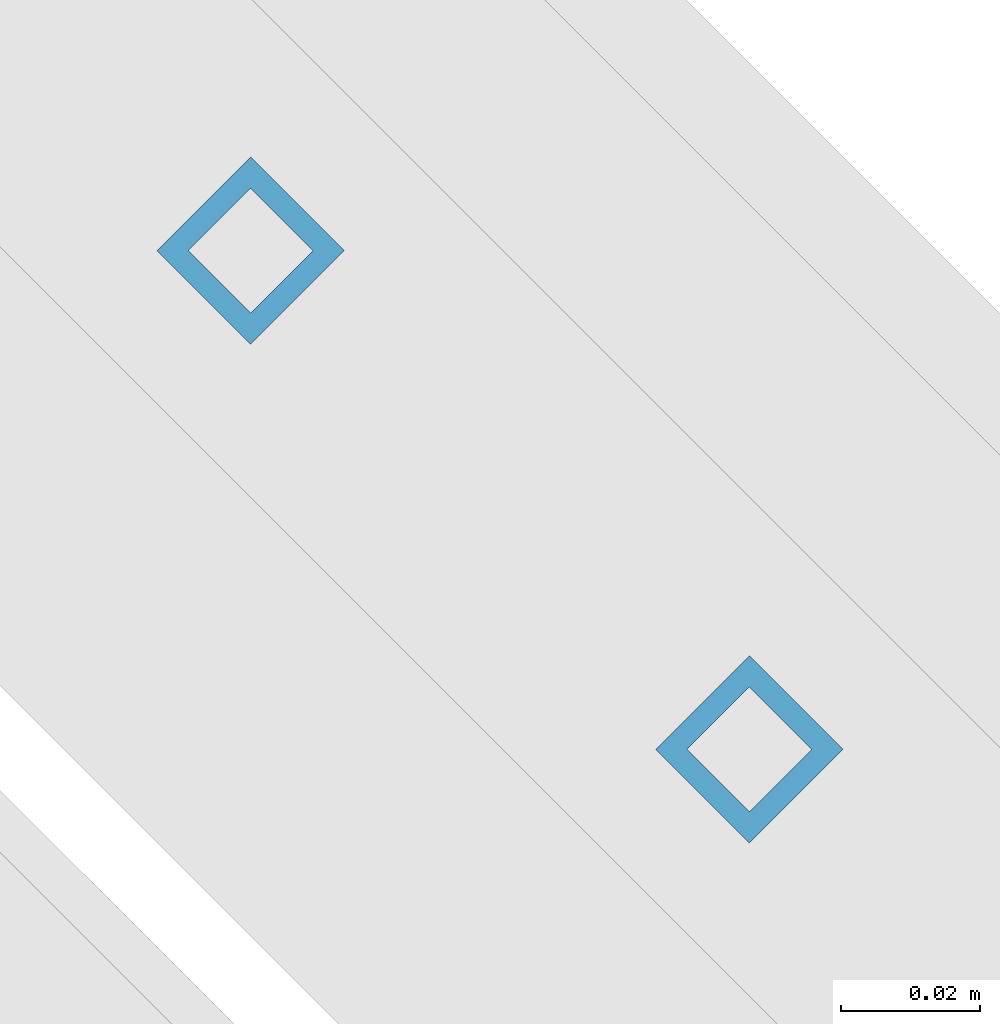
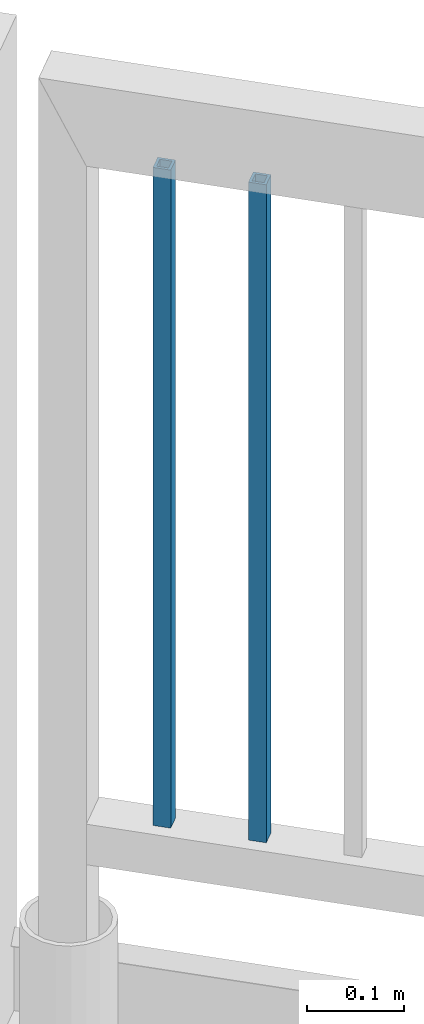
# One storey, part 247 of 975: 2 columns.
"""IFC2X3 building model written with IfcOpenShell, lengths in millimetres."""

from ifc_helpers import new_model, si_unit, frame, origin_with_axes, place, context, subcontext, project, spatial, faceted_brep, material, type_object, element, save


model = new_model("IFC2X3")

# Units and contexts
model_context = context("Model", 3, precision=1e-05, world=origin_with_axes())
body_context = subcontext(model_context, "Body", "Model", "MODEL_VIEW")
ifc_project = project(units=[si_unit("LENGTHUNIT", "METRE", prefix="MILLI"), si_unit("AREAUNIT", "SQUARE_METRE"), si_unit("VOLUMEUNIT", "CUBIC_METRE"), si_unit("MASSUNIT", "GRAM", prefix="KILO"), si_unit("TIMEUNIT", "SECOND"), si_unit("PLANEANGLEUNIT", "RADIAN"), si_unit("SOLIDANGLEUNIT", "STERADIAN"), si_unit("THERMODYNAMICTEMPERATUREUNIT", "DEGREE_CELSIUS"), si_unit("LUMINOUSINTENSITYUNIT", "LUMEN")], contexts=[model_context])

# Site, building, storey
site_placement = place(None, origin_with_axes())
site = spatial("IfcSite", under=ifc_project, at=site_placement, CompositionType="ELEMENT")
building_placement = place(site_placement, origin_with_axes())
building = spatial("IfcBuilding", under=site, at=building_placement, Name="Undefined", CompositionType="ELEMENT")
storey_placement = place(building_placement, origin_with_axes())
storey = spatial("IfcBuildingStorey", under=building, at=storey_placement, Name="Undefined", CompositionType="ELEMENT", Elevation=0.0)

# Columns
ifc_material = material()
column_type = type_object("IfcColumnType", Name="HSS3/4X3/4X.120_TUBES", PredefinedType="NOTDEFINED")
for number, where, z_axis, x_axis, name in (
    (1, (27582.5307259871, 21052.0942992216, 4254.49914984075), (-0.707106781186601, 0.707106781186494, 2.36468622460961e-14), (0.0, 0.0, 1.0), "PICKET"),
    (2, (27654.3651009871, 20980.2599242216, 4254.49914984075), (-0.707106781186601, 0.707106781186494, 2.36468622460961e-14), (0.0, 0.0, 1.0), "PICKET"),
):
    element("IfcColumn", number, at=place(storey_placement, frame(where, z_axis=z_axis, x_axis=x_axis)), inside=storey, type_object=column_type, material=ifc_material, Name=name, ObjectType="HSS3/4X3/4X.120_TUBES", context=body_context, shape_type="Brep", body=[
        faceted_brep([(0.0, 6.34999999998763, -6.34999999998763), (0.0, -6.35000000000582, -6.34999999998763), (825.49997943247, -6.35000000000582, -6.34999999998763), (825.49997943247, 6.34999999998763, -6.34999999998763), (0.0, -6.34999999998763, 6.34999999998763), (825.49997943247, -6.34999999998763, 6.34999999998763), (0.0, 6.35000000000946, 6.34999999998763), (825.49997943247, 6.35000000000946, 6.34999999998763), (0.0, 9.52499999997963, -9.52499999997963), (0.0, 9.52500000000873, 9.5249999999869), (825.49997943247, 9.52500000000873, 9.5249999999869), (825.49997943247, 9.52499999997963, -9.52499999997963), (0.0, -9.52499999997963, 9.52499999998327), (825.49997943247, -9.52499999997963, 9.52499999998327), (0.0, -9.52500000000873, -9.5249999999869), (825.49997943247, -9.52500000000873, -9.5249999999869)], [[[0, 1, 2, 3]], [[1, 4, 5, 2]], [[4, 6, 7, 5]], [[6, 0, 3, 7]], [[8, 9, 10, 11]], [[9, 12, 13, 10]], [[12, 14, 15, 13]], [[14, 8, 11, 15]], [[13, 15, 11, 10], [5, 7, 3, 2]], [[14, 12, 9, 8], [6, 4, 1, 0]]]),
    ])

save(model, "model.ifc")
